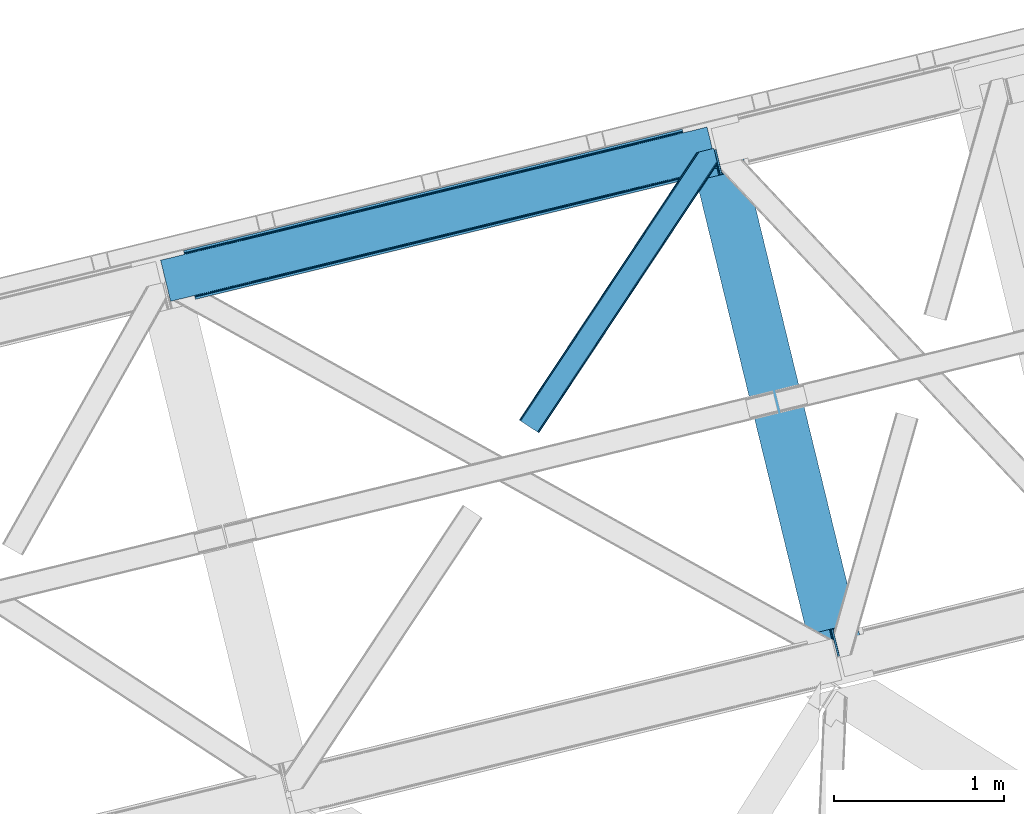
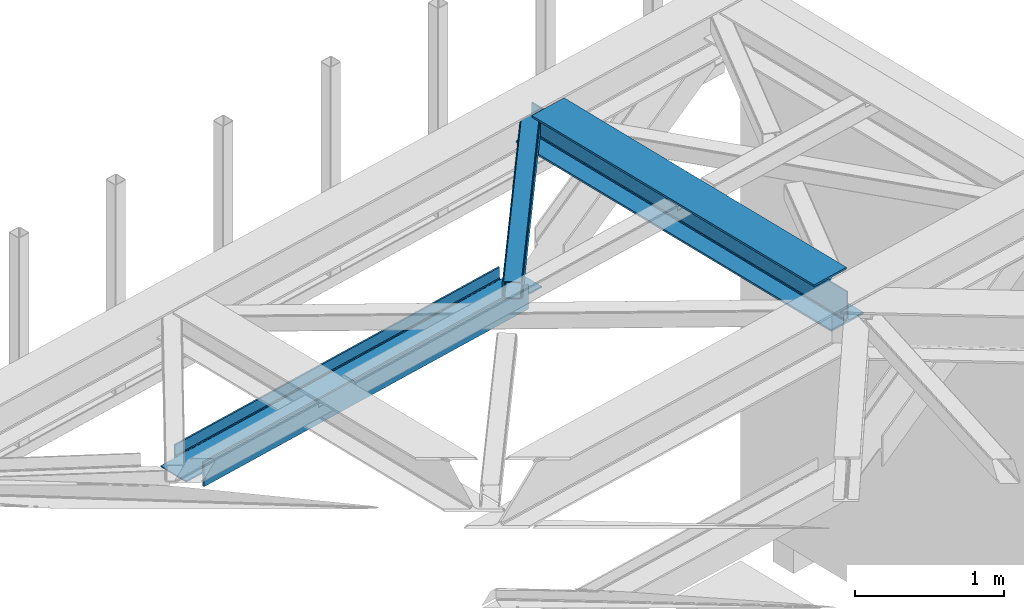
# One storey, part 60 of 66: 2 members, 1 beam.
"""IFC4 building model written with IfcOpenShell, lengths in millimetres."""

from ifc_helpers import new_model, entity, si_unit, converted_unit, derived_unit, direction, frame, origin, place, context, subcontext, project, spatial, triangles, polygons, material, type_object, element, save


model = new_model("IFC4")

# Units and contexts
model_context = context("Model", 3, precision=0.01, world=origin(), true_north=direction((6.12303176911189e-17, 1.0)))
plan_context = context("Plan", 3, precision=0.01, world=origin(), true_north=direction((6.12303176911189e-17, 1.0)))
body_context = subcontext(model_context, "Body", "Model", "MODEL_VIEW")
ifc_project = project(units=[si_unit("LENGTHUNIT", "METRE", prefix="MILLI"), si_unit("AREAUNIT", "SQUARE_METRE"), si_unit("VOLUMEUNIT", "CUBIC_METRE"), converted_unit("PLANEANGLEUNIT", "DEGREE", entity("IfcRatioMeasure", 0.0174532925199433), si_unit("PLANEANGLEUNIT", "RADIAN"), dimensions=[0, 0, 0, 0, 0, 0, 0]), si_unit("MASSUNIT", "GRAM", prefix="KILO"), derived_unit("MASSDENSITYUNIT", [(si_unit("MASSUNIT", "GRAM", prefix="KILO"), 1), (si_unit("LENGTHUNIT", "METRE"), -3)]), derived_unit("MOMENTOFINERTIAUNIT", [(si_unit("LENGTHUNIT", "METRE"), 4)]), si_unit("TIMEUNIT", "SECOND"), si_unit("FREQUENCYUNIT", "HERTZ"), si_unit("THERMODYNAMICTEMPERATUREUNIT", "DEGREE_CELSIUS"), derived_unit("THERMALTRANSMITTANCEUNIT", [(si_unit("MASSUNIT", "GRAM", prefix="KILO"), 1), (si_unit("THERMODYNAMICTEMPERATUREUNIT", "KELVIN"), -1), (si_unit("TIMEUNIT", "SECOND"), -3)]), derived_unit("VOLUMETRICFLOWRATEUNIT", [(si_unit("LENGTHUNIT", "METRE"), 3), (si_unit("TIMEUNIT", "SECOND"), -1)]), derived_unit("MASSFLOWRATEUNIT", [(si_unit("MASSUNIT", "GRAM", prefix="KILO"), 1), (si_unit("TIMEUNIT", "SECOND"), -1)]), derived_unit("ROTATIONALFREQUENCYUNIT", [(si_unit("TIMEUNIT", "SECOND"), -1)]), si_unit("ELECTRICCURRENTUNIT", "AMPERE"), si_unit("ELECTRICVOLTAGEUNIT", "VOLT"), si_unit("POWERUNIT", "WATT"), si_unit("FORCEUNIT", "NEWTON", prefix="KILO"), si_unit("ILLUMINANCEUNIT", "LUX"), si_unit("LUMINOUSFLUXUNIT", "LUMEN"), si_unit("LUMINOUSINTENSITYUNIT", "CANDELA"), derived_unit("USERDEFINED", [(si_unit("MASSUNIT", "GRAM", prefix="KILO"), -1), (si_unit("LENGTHUNIT", "METRE"), -2), (si_unit("TIMEUNIT", "SECOND"), 3), (si_unit("LUMINOUSFLUXUNIT", "LUMEN"), 1)]), derived_unit("LINEARVELOCITYUNIT", [(si_unit("LENGTHUNIT", "METRE"), 1), (si_unit("TIMEUNIT", "SECOND"), -1)]), si_unit("PRESSUREUNIT", "PASCAL"), derived_unit("USERDEFINED", [(si_unit("LENGTHUNIT", "METRE"), -2), (si_unit("MASSUNIT", "GRAM", prefix="KILO"), 1), (si_unit("TIMEUNIT", "SECOND"), -2)]), derived_unit("LINEARFORCEUNIT", [(si_unit("MASSUNIT", "GRAM", prefix="KILO"), 1), (si_unit("LENGTHUNIT", "METRE"), 1), (si_unit("TIMEUNIT", "SECOND"), -2), (si_unit("LENGTHUNIT", "METRE"), -1)]), derived_unit("PLANARFORCEUNIT", [(si_unit("MASSUNIT", "GRAM", prefix="KILO"), 1), (si_unit("LENGTHUNIT", "METRE"), 1), (si_unit("TIMEUNIT", "SECOND"), -2), (si_unit("LENGTHUNIT", "METRE"), -2)])], contexts=[model_context, plan_context])

# Site, building, storey
site_placement = place(None, origin())
site = spatial("IfcSite", under=ifc_project, at=site_placement, CompositionType="ELEMENT")
building_placement = place(site_placement, origin())
building = spatial("IfcBuilding", under=site, at=building_placement, CompositionType="ELEMENT")
storey_placement = place(building_placement, frame((0.0, 0.0, 19800.0)))
storey = spatial("IfcBuildingStorey", under=building, at=storey_placement, Name="06", CompositionType="ELEMENT", Elevation=19800.0)

# Beam
ifc_material = material(Name="Metal painted (White)")
beam_type = type_object("IfcBeamType", PredefinedType="BEAM")
beam_placement = place(storey_placement, frame((-3043.28, 17053.1, 3807.02)))
element("IfcBeam", 1, at=beam_placement, inside=storey, type_object=beam_type, material=ifc_material, ObjectType="Steel Beam", PredefinedType="BEAM", context=body_context, shape_type="Tessellation", body=[
    polygons([(1018.16648378329, 71.0478278971, 15.5000000000008), (1018.16648378329, 71.0478278971, 0.0), (291.465617442441, 3052.25531830421, 0.0), (291.46561744244, 3052.25531830421, 15.5000000000008), (894.779372399327, 40.970914087327, 15.5000000000008), (168.078506058477, 3022.17840449444, 15.5000000000008), (888.087028625373, 39.3395844888221, 16.8701684147984), (161.386162284522, 3020.54707489593, 16.8701684147984), (882.413533524753, 37.9566100336519, 20.7720779386391), (155.712667183902, 3019.16410044076, 20.7720779386391), (878.622625296174, 37.032536045914, 26.6116982174294), (151.921758955324, 3018.24002645303, 26.6116982174294), (877.29143535278, 36.7080444135029, 33.500000000001), (150.59056901193, 3017.91553482061, 33.500000000001), (140.875048430515, 3015.54727389071, 33.500000000001), (140.875048430516, 3015.54727389071, 259.000000000002), (150.590569011928, 3017.91553482061, 259.000000000002), (5.41433564649196e-13, 2981.20749040711, 0.0), (1.08286712929839e-12, 2981.20749040711, 15.4999999999965), (123.387111383957, 3011.28440421688, 15.5000000000008), (130.079455157929, 3012.91573381539, 16.8701684147984), (135.752950258545, 3014.29870827056, 20.7720779386391), (139.543858487118, 3015.22278225829, 26.6116982174294), (877.291435352778, 36.7080444135029, 259.000000000002), (867.575914771367, 34.3397834835992, 259.000000000002), (867.575914771365, 34.3397834835992, 33.500000000001), (866.244724827968, 34.0152918511816, 26.6116982174294), (862.453816599396, 33.0912178634502, 20.7720779386391), (856.78032149878, 31.70824340828, 16.8701684147984), (850.087977724808, 30.0769138097708, 15.5000000000008), (726.700866340852, -2.16573425859679e-12, 15.4999999999965), (726.700866340851, -2.16573425859679e-12, 0.0), (838.124523615906, 197.385937999179, 259.069791973884), (186.469722099963, 2870.72539801218, 259.000000000002), (186.693115201815, 2869.8089536072, 259.617303331124), (186.705504045442, 2869.75812937344, 266.500003008253), (837.97934480814, 197.9814160017, 266.500002998871), (837.979694928892, 197.979979696968, 260.000004007589), (828.499586345875, 194.645865944432, 259.006343171919), (828.276216326112, 195.562317481909, 259.617303331124), (828.263827482483, 195.613141715687, 266.500003008253), (176.989986719785, 2867.38985508742, 266.500002998871), (176.989636599033, 2867.39129139215, 260.000004007589), (176.844830940693, 2867.98534020594, 259.07612046749), (176.754201518551, 2868.35713708228, 259.000000000002), (839.310832678069, 198.30468544639, 273.388305639783), (843.101109266761, 199.231350618303, 279.227924098781), (848.7741802143, 200.616065081979, 283.129832400619), (855.466371895431, 202.248018612794, 284.500000377228), (978.853400583269, 232.325271667903, 284.500000138971), (978.851730776618, 232.332121736637, 299.999995328161), (687.386308679348, 161.283492472594, 299.999995890962), (687.387978485999, 161.276642403861, 284.500000701776), (810.775007173834, 191.35389545897, 284.500000463519), (817.467494069994, 192.984637925553, 283.129832461069), (823.141405718745, 194.365903570076, 279.227924137322), (826.932940505739, 195.28740721937, 273.388305663684), (175.658498849857, 2867.06658564273, 273.388305639783), (171.868222261161, 2866.13992047082, 279.227924098781), (166.195151313635, 2864.75520600714, 283.129832400619), (159.502959632485, 2863.12325247633, 284.500000377228), (36.115930944656, 2833.04599942122, 284.500000138971), (36.117600751305, 2833.03914935249, 299.999995328161), (327.583022848576, 2904.08777861653, 299.999995890962), (327.581353041926, 2904.09462868526, 284.500000701776), (204.194324354083, 2874.01737563015, 284.500000463519), (197.501837457941, 2872.38663316357, 283.129832461069), (191.827925809177, 2871.00536751904, 279.227924137322), (188.036391022187, 2870.08386386975, 273.388305663684)], [[[1, 2, 3, 4]], [[5, 1, 4, 6]], [[7, 5, 6, 8]], [[9, 7, 8, 10]], [[11, 9, 10, 12]], [[13, 11, 12, 14]], [[15, 16, 17, 14, 12, 10, 8, 6, 4, 3, 18, 19, 20, 21, 22, 23]], [[13, 24, 25, 26, 27, 28, 29, 30, 31, 32, 2, 1, 5, 7, 9, 11]], [[2, 32, 18, 3]], [[32, 31, 19, 18]], [[31, 30, 20, 19]], [[27, 26, 15, 23]], [[28, 27, 23, 22]], [[29, 28, 22, 21]], [[30, 29, 21, 20]], [[33, 24, 13, 14, 17, 34, 35, 36, 37, 38]], [[25, 39, 40, 41, 42, 43, 44, 16, 15, 26]], [[39, 25, 24, 33]], [[45, 34, 17, 16]], [[41, 40, 38, 37, 46, 47, 48, 49, 50, 51, 52, 53, 54, 55, 56, 57]], [[42, 58, 59, 60, 61, 62, 63, 64, 65, 66, 67, 68, 69, 36, 35, 43]], [[46, 37, 36, 69]], [[47, 46, 69, 68]], [[48, 47, 68, 67]], [[49, 48, 67, 66]], [[50, 49, 66, 65]], [[51, 50, 65, 64]], [[52, 51, 64, 63]], [[53, 52, 63, 62]], [[54, 53, 62, 61]], [[55, 54, 61, 60]], [[56, 55, 60, 59]], [[57, 56, 59, 58]], [[41, 57, 58, 42]]], closed=False),
])

# Members
member_type_1 = type_object("IfcMemberType", PredefinedType="BRACE")
member_1_placement = place(storey_placement, frame((-4050.77, 18401.58, 3823.02)))
element("IfcMember", 2, at=member_1_placement, inside=storey, type_object=member_type_1, ObjectType="Steel Horizontal Brace", PredefinedType="BRACE", context=body_context, shape_type="Tessellation", body=[
    triangles([(1012.13822021484, 1571.4587310791, 0.0), (1045.99690933228, 1432.55790710449, 0.0), (14.5796333312987, 67.7191223144546, 0.0), (102.080397033692, 9.67499084472729, 0.0), (1.10807189941397, 76.6569488525383, 10.8016662597656), (0.0, 77.3929504394546, 17.4989318847656), (1043.79529953003, 1650.83760681152, 17.4989318847656), (1007.73296585083, 1592.73185119629, 9.25757446288844), (4.27125091552716, 74.5605651855476, 5.12526855468604), (1007.87191085815, 1593.1829864502, 9.49942016601563), (1007.5829750061, 1592.24815979004, 8.99945068359375), (1007.43734436035, 1591.76446838379, 8.74132690429542), (1007.29839935303, 1591.31333312989, 8.49948120117188), (1008.14776611328, 1587.8298248291, 5.12526855468604), (1046.0907989502, 1651.39571228027, 10.8691040039048), (1046.56518859863, 1651.51198425293, 9.49942016601563), (1009.97875900269, 1580.31865539551, 1.33247680663771), (9.00003204345694, 71.4212219238289, 1.33247680663771), (1043.79529953003, 1650.83760681152, 122.499499511716), (0.0, 77.3929504394546, 122.499499511716), (1045.70215988159, 1651.30269470215, 129.196765136716), (1.10807189941397, 76.6569488525383, 129.196765136716), (1051.1335144043, 1652.62586975098, 134.873162841795), (4.27125091552716, 74.5605651855476, 134.873162841795), (1059.25772781372, 1654.60481872559, 138.668280029295), (9.00003204345694, 71.4212219238289, 138.668280029295), (1068.84609603882, 1656.94421081543, 139.998431396481), (14.5796333312987, 67.7191223144546, 139.998431396481), (1012.24141159058, 1575.25849914551, 9.49942016601563), (1011.99578704834, 1574.65621032715, 9.42268066406177), (1012.03008728027, 1573.63069152832, 9.11572265625), (1012.0707824707, 1572.60052185059, 8.80643920898365), (1012.10973358154, 1571.57732849121, 8.49948120117188), (1065.96342315674, 1656.23960266114, 9.49942016601563), (14.8357223510743, 67.5516906738303, 8.33204956054396), (20.4150329589843, 63.8495910644524, 6.99957275390625), (1014.39534988403, 1562.19883117676, 6.99957275390625), (10.1022903442381, 70.6898712158218, 12.1248413085923), (1061.15121688843, 1655.06758117676, 12.1248413085923), (1012.24228363037, 1571.03317565918, 8.41343994140334), (1055.7242225647, 1653.74440612793, 17.8035644531228), (1053.81300201416, 1653.27931823731, 24.4985046386719), (6.94376220703134, 72.7874176025398, 17.8035644531228), (5.83074874877912, 73.5234191894524, 24.4985046386719), (1043.73948898315, 1441.81780700684, 6.99957275390625), (96.244997406006, 13.5445220947258, 6.99957275390625), (1045.89284591675, 1432.98578796387, 8.41343994140334), (1046.02539596558, 1432.44163513184, 8.49948120117188), (1050.83643951416, 1412.70330505371, 8.49948120117188), (1049.98707275391, 1416.18913879395, 5.12526855468604), (1048.15637054443, 1423.69798278809, 1.33247680663771), (1053.81300201416, 1653.27931823731, 115.49992675781), (5.83074874877912, 73.5234191894524, 115.49992675781), (1069.28008117676, 1657.04885559082, 131.666381835938), (1078.86844940186, 1659.38592224121, 132.998858642575), (20.4150329589843, 63.8495910644524, 132.998858642575), (14.8357223510743, 67.5516906738303, 131.666381835938), (1061.15121688843, 1655.06758117676, 127.873590087889), (10.1022903442381, 70.6898712158218, 127.873590087889), (1055.7242225647, 1653.74440612793, 122.19719238281), (6.94376220703134, 72.7874176025398, 122.19719238281), (1145.26875686646, 1675.57098083496, 139.998431396481), (1145.26875686646, 1675.57098083496, 132.998858642575), (1161.91250839233, 1607.29375305176, 139.998431396481), (102.080397033692, 9.67499084472729, 139.998431396481), (1159.65537872314, 1616.5536529541, 132.998858642575), (96.244997406006, 13.5445220947258, 132.998858642575), (1164.07226028442, 1598.43382873535, 138.668280029295), (107.659998321533, 5.97289123535302, 138.668280029295), (1165.9029624939, 1590.92265930176, 134.873162841795), (112.388779449463, 2.83354797363427, 134.873162841795), (1167.12614364624, 1585.90436096191, 129.196765136716), (115.551958465576, 0.737164306639897, 129.196765136716), (1167.55576858521, 1584.14167785645, 122.499499511716), (116.660321044922, 0.0, 122.499499511716), (1167.55576858521, 1584.14167785645, 17.4989318847656), (116.660321044922, 0.0, 17.4989318847656), (106.557740020752, 6.7042419433601, 127.873590087889), (109.716268157959, 4.60553283691479, 122.19719238281), (110.829281616211, 3.87069396972583, 115.49992675781), (101.824308013916, 9.84125976562427, 131.666381835938), (115.551958465576, 0.737164306639897, 10.8016662597656), (106.557740020752, 6.7042419433601, 12.1248413085923), (112.388779449463, 2.83354797363427, 5.12526855468604), (110.829281616211, 3.87069396972583, 24.4985046386719), (109.716268157959, 4.60553283691479, 17.8035644531228), (107.659998321533, 5.97289123535302, 1.33247680663771), (101.824308013916, 9.84125976562427, 8.33204956054396), (1165.29834823608, 1593.40157775879, 115.49992675781), (1165.29834823608, 1593.40157775879, 24.4985046386719), (1164.86901397705, 1595.16426086426, 122.19719238281), (1163.64554214478, 1600.1825592041, 127.873590087889), (1161.8148399353, 1607.6937286377, 131.666381835938), (1164.7812286377, 1595.52470397949, 17.868676757811), (1167.54646682739, 1584.18121032715, 16.4989929199219), (1164.67425842285, 1595.96188659668, 16.4989929199219), (1050.96404800415, 1412.49401550293, 8.8831787109375), (1051.5055847168, 1412.90561828614, 9.29943237304542), (1051.768359375, 1413.10328063965, 9.49942016601563), (1162.81652297974, 1579.82333679199, 10.8714294433594), (1161.66310501099, 1578.76061096192, 9.49942016601563), (1160.35097579956, 1595.22007141114, 12.1248413085923), (1046.70355224609, 1430.89521789551, 9.20641479492042), (1046.36229400635, 1431.66726379394, 8.85294799804615), (1047.39885864258, 1431.02776794434, 9.49942016601563), (1157.29360427856, 1596.68742370605, 9.49942016601563)], [[1, 2, 3], [4, 3, 2], [5, 6, 7], [8, 9, 10], [9, 8, 11], [12, 9, 11], [9, 12, 13], [13, 14, 9], [5, 15, 10], [10, 9, 5], [15, 16, 10], [17, 1, 18], [3, 18, 1], [14, 17, 9], [18, 9, 17], [7, 15, 5], [19, 7, 6], [6, 20, 19], [21, 19, 22], [20, 22, 19], [23, 21, 24], [22, 24, 21], [25, 23, 26], [24, 26, 23], [27, 25, 28], [26, 28, 25], [8, 10, 29], [11, 8, 30], [12, 11, 31], [13, 12, 32], [32, 33, 13], [31, 32, 12], [30, 31, 11], [29, 30, 8], [16, 34, 29], [29, 10, 16], [35, 36, 37], [38, 30, 29], [29, 39, 38], [29, 34, 39], [38, 35, 40], [40, 33, 38], [31, 38, 32], [31, 30, 38], [38, 33, 32], [37, 40, 35], [41, 42, 43], [44, 43, 42], [39, 41, 38], [43, 38, 41], [45, 37, 36], [36, 46, 45], [1, 37, 45], [13, 33, 14], [33, 40, 1], [37, 1, 40], [33, 17, 14], [33, 1, 17], [2, 1, 45], [2, 45, 47], [48, 2, 47], [49, 50, 48], [48, 51, 2], [48, 50, 51], [42, 52, 44], [53, 44, 52], [54, 55, 56], [56, 57, 54], [58, 54, 57], [57, 59, 58], [60, 58, 59], [59, 61, 60], [52, 60, 61], [61, 53, 52], [60, 19, 21], [54, 25, 27], [62, 55, 27], [55, 62, 63], [55, 54, 27], [58, 25, 54], [58, 60, 23], [23, 25, 58], [21, 23, 60], [42, 7, 19], [39, 16, 41], [60, 52, 19], [39, 34, 16], [42, 41, 7], [52, 42, 19], [15, 7, 41], [41, 16, 15], [64, 27, 65], [27, 64, 62], [28, 65, 27], [55, 66, 67], [55, 63, 66], [67, 56, 55], [68, 64, 65], [65, 69, 68], [70, 68, 69], [69, 71, 70], [72, 70, 71], [71, 73, 72], [74, 72, 73], [73, 75, 74], [76, 74, 77], [75, 77, 74], [73, 78, 79], [80, 77, 75], [73, 79, 75], [73, 71, 78], [79, 80, 75], [78, 71, 69], [67, 65, 28], [65, 81, 69], [81, 65, 67], [81, 78, 69], [82, 83, 84], [85, 77, 80], [77, 86, 82], [86, 77, 85], [82, 86, 83], [4, 46, 3], [87, 84, 83], [83, 88, 87], [88, 46, 4], [4, 87, 88], [59, 26, 24], [28, 56, 67], [28, 57, 56], [57, 28, 26], [59, 57, 26], [53, 20, 6], [22, 61, 59], [24, 22, 59], [61, 22, 20], [53, 61, 20], [18, 38, 9], [3, 46, 36], [36, 35, 3], [35, 38, 18], [18, 3, 35], [5, 9, 38], [6, 44, 53], [43, 6, 5], [6, 43, 44], [43, 5, 38], [89, 90, 85], [85, 80, 89], [91, 89, 79], [80, 79, 89], [92, 91, 78], [79, 78, 91], [93, 92, 81], [78, 81, 92], [66, 93, 67], [81, 67, 93], [94, 95, 96], [74, 76, 90], [76, 94, 90], [90, 89, 74], [76, 95, 94], [91, 74, 89], [72, 74, 91], [70, 91, 92], [91, 70, 72], [92, 68, 70], [93, 68, 92], [93, 66, 64], [93, 64, 68], [66, 62, 64], [66, 63, 62], [82, 97, 98], [99, 100, 82], [99, 101, 100], [84, 50, 97], [97, 82, 84], [77, 82, 100], [100, 76, 77], [100, 95, 76], [51, 50, 87], [84, 87, 50], [2, 51, 4], [87, 4, 51], [86, 85, 90], [86, 96, 102], [86, 94, 96], [103, 104, 88], [48, 88, 104], [83, 102, 105], [105, 88, 83], [102, 106, 105], [46, 88, 48], [48, 45, 46], [102, 83, 86], [90, 94, 86], [97, 48, 104], [97, 104, 105], [106, 101, 105], [99, 105, 101], [102, 95, 100], [102, 96, 95], [102, 101, 106], [100, 101, 102]]),
])
member_type_2 = type_object("IfcMemberType", PredefinedType="BRACE")
member_2_placement = place(storey_placement, frame((-6161.17, 19176.73, 2512.0)))
element("IfcMember", 3, at=member_2_placement, inside=storey, type_object=member_type_2, ObjectType="Steel Vertical Brace", PredefinedType="BRACE", context=body_context, shape_type="Tessellation", body=[
    polygons([(202.213006515029, 24.6242629021849, 77.7499999999953), (597.31084349256, 120.933540718255, 77.7499999999953), (1133.2837289006, 251.582602017925, 77.7499999999953), (1669.25661430864, 382.231663317597, 77.7499999999953), (2205.22949971669, 512.88072461726, 77.7499999999953), (2741.20238512474, 643.529785916932, 77.7499999999953), (3136.30022210225, 739.839063732998, 77.7499999999953), (3136.30022210225, 739.839063732998, 0.0), (202.213006515025, 24.6242629021849, 0.0), (3139.37896131113, 727.208886977162, 0.0), (205.291745723899, 11.9940861463463, 0.0), (3139.37896131113, 727.208886977162, 199.999999999998), (205.291745723903, 11.9940861463485, 199.999999999998), (3136.30022210225, 739.839063732998, 122.249999999994), (3136.30022210225, 739.839063732998, 199.999999999998), (3135.97573046984, 741.170253676395, 84.6383017825712), (3135.0516564821, 744.96116190497, 90.4779220613573), (3133.93196117233, 749.554584314495, 93.8745154964792), (3133.93196117236, 749.554584314417, 106.125484503402), (3135.0516564821, 744.96116190497, 109.522077938641), (3135.97573046984, 741.170253676395, 115.361698217427), (202.213006515033, 24.6242629021892, 122.249999999994), (201.888514882618, 25.9554528455858, 115.361698217427), (200.964440894883, 29.7463610741609, 109.522077938641), (199.844745585119, 34.339783483636, 106.125484503441), (199.844745585126, 34.3397834836057, 93.8745154965962), (200.964440894884, 29.7463610741609, 90.4779220613573), (201.888514882619, 25.9554528455858, 84.6383017825712), (202.213006515033, 24.6242629021892, 199.999999999998), (2634.00780804313, 617.399973656999, 122.249999999994), (1990.84034555346, 460.621100097393, 122.249999999994), (1347.67288306381, 303.842226537792, 122.249999999994), (704.505420574163, 147.063352978191, 122.249999999994), (2738.57084504939, 654.325379189628, 94.3798315850377), (2736.93951545091, 661.017722963482, 95.7499999999999), (3272.91240085895, 791.66678426315, 95.7499999999999), (3274.54373045746, 784.9744404892, 94.3798315851979), (2202.59795964137, 523.676317889856, 94.3798315852023), (2200.96663004286, 530.36866166381, 95.7499999999999), (1666.62507423332, 393.027256590189, 94.3798315852023), (1664.99374463482, 399.719600364143, 95.7499999999999), (1130.65218882528, 262.378195290517, 94.3798315852023), (1129.02085922678, 269.070539064473, 95.7499999999999), (594.679303417239, 131.729133990851, 94.3798315852023), (593.047973818735, 138.421477764808, 95.7499999999999), (58.7064180091819, 1.08007269117741, 94.3798315852023), (57.075088410676, 7.77241646513144, 95.7499999999999), (2203.98093409654, 518.002822789236, 90.4779220613573), (2739.95381950459, 648.651884088908, 90.4779220613573), (1668.00804868849, 387.353761489569, 90.4779220613573), (1132.03516328045, 256.704700189899, 90.4779220613573), (596.062277872437, 126.055638890125, 90.4779220615175), (2204.90500808427, 514.211914560661, 84.6383017825712), (2740.87789349232, 644.860975860333, 84.6383017825712), (1668.93212267623, 383.562853260994, 84.6383017825712), (1132.95923726819, 252.913791961324, 84.6383017825712), (596.986351860145, 122.264730661656, 84.6383017825712), (58.9696971545985, 6.49720277579036e-12, 93.8745154965962), (3274.80700960288, 783.894367798018, 93.8745154965962), (1990.51585392106, 461.952290040794, 115.361698217427), (2633.68331641071, 618.731163600395, 115.361698217427), (1347.34839143141, 305.173416481191, 115.361698217427), (704.180928941749, 148.394542921588, 115.361698217427), (1989.59177993332, 465.743198269369, 109.522077938641), (2632.75924242298, 622.522071828931, 109.522077938576), (1346.42431744367, 308.964324709768, 109.522077938641), (703.256854954015, 152.185451150165, 109.522077938641), (1988.20880547815, 471.416693369989, 105.620168414796), (2631.3762679678, 628.19556692959, 105.620168414796), (1345.0413429885, 314.637819810386, 105.620168414796), (701.873880498833, 157.858946250817, 105.620168414861), (2629.7449383693, 634.887910703549, 104.249999999998), (3274.54373045746, 784.974440489196, 105.620168414796), (3272.91240085896, 791.66678426315, 104.249999999998), (1986.57747587964, 478.109037143939, 104.249999999998), (1343.41001338999, 321.33016358434, 104.249999999998), (700.242550900338, 164.551290024739, 104.249999999998), (57.0750884106738, 7.77241646513144, 104.249999999998), (58.7064180091873, 1.08007269117957, 105.6201684148), (3274.80700960287, 783.894367798018, 106.125484503402), (58.9696971545985, 0.0, 106.125484503397), (3217.73192119221, 1018.03841381011, 95.7499999999999), (3216.10059159371, 1024.73075758407, 94.3798315852023), (3215.83731244829, 1025.81083027525, 93.8745154965962), (3215.83731244829, 1025.81083027525, 106.125484503397), (3216.10059159371, 1024.73075758407, 105.620168414796), (3217.73192119221, 1018.03841381011, 104.250000000002), (1.89460874392469, 234.144046012093, 104.250000000002), (0.263279145419858, 240.836389786054, 105.620168414796), (1.08286712929839e-12, 241.916462477225, 106.125484503402), (1.08286712929839e-12, 241.916462477225, 93.8745154965962), (0.26327914542419, 240.836389786054, 94.3798315852023), (1.89460874392469, 234.144046012093, 95.7499999999999), (645.06207123359, 390.922919571701, 95.7499999999999), (1288.22953372324, 547.701793131302, 95.7499999999999), (1931.39699621289, 704.480666690907, 95.7499999999999), (2574.56445870255, 861.259540250508, 95.7499999999999), (2681.75903578416, 887.389352510442, 104.250000000002), (2145.78615037611, 756.740291210774, 104.250000000002), (1609.81326496807, 626.091229911107, 104.250000000002), (1073.84037956003, 495.442168611439, 104.250000000002), (537.867494151986, 364.793107311767, 104.250000000002), (1927.45861817149, 720.637413794056, 84.6383017825712), (1927.13412653906, 721.968603737453, 77.7499999999953), (2570.30158902872, 878.747477297058, 77.7499999999953), (2570.62608066114, 877.416287353657, 84.6383017825712), (1284.29115568184, 563.858540234455, 84.6383017825712), (1283.96666404941, 565.189730177852, 77.7499999999953), (641.123693192179, 407.07966667485, 84.6383017825712), (640.799201559763, 408.410856618251, 77.7499999999953), (1928.38269215922, 716.846505565486, 90.4779220613573), (2571.55015464886, 873.625379125126, 90.4779220614179), (1285.21522966957, 560.06763200588, 90.4779220613573), (642.047767179914, 403.288758446279, 90.4779220613573), (1929.76566661439, 711.173010464866, 94.3798315852023), (2572.93312910405, 867.951884024467, 94.3798315852023), (1286.59820412474, 554.39413690526, 94.3798315852023), (643.430741635095, 397.615263345616, 94.3798315851416), (3072.59400308785, 1001.18656737306, 77.7499999999953), (3072.91849472027, 999.855377429661, 84.6383017825712), (3073.84256870799, 996.064469201147, 90.4779220614439), (3074.96226401778, 991.471046791609, 93.8745154965442), (139.755353120759, 280.849668370334, 90.4779220614439), (138.831279133037, 284.640576598848, 84.6383017825712), (138.506787500627, 285.971766542245, 77.7499999999953), (140.875048430544, 276.25624596077, 93.8745154965052), (2680.12770618568, 894.081696284296, 105.620168414956), (2144.15482077761, 763.432634984733, 105.620168414796), (1608.18193536956, 632.783573685065, 105.620168414796), (1072.20904996152, 502.134512385398, 105.620168414796), (536.236164553481, 371.48545108573, 105.620168414796), (2142.77184632243, 769.106130085348, 109.522077938641), (2678.74473173049, 899.755191385025, 109.522077938641), (1606.79896091439, 638.457068785685, 109.522077938641), (1070.82607550635, 507.808007486013, 109.522077938641), (534.853190098284, 377.158946186454, 109.522077938476), (2141.8477723347, 772.897038313923, 115.361698217427), (2677.82065774275, 903.546099613591, 115.361698217427), (1605.87488692666, 642.247977014256, 115.361698217427), (1069.90200151862, 511.598915714588, 115.361698217427), (533.929116110575, 380.949854414921, 115.361698217427), (2141.52328070228, 774.22822825732, 122.249999999994), (2677.49616611034, 904.877289556988, 122.249999999994), (1605.55039529424, 643.579166957652, 122.249999999994), (1069.5775098862, 512.930105657985, 122.249999999994), (533.60462447816, 382.281044358317, 122.249999999994), (3073.84256870796, 996.064469201242, 109.522077938415), (3072.91849472027, 999.855377429661, 115.361698217427), (3072.59400308785, 1001.18656737306, 122.249999999994), (138.506787500631, 285.971766542245, 122.249999999994), (138.831279133042, 284.640576598848, 115.361698217427), (139.755353120737, 280.849668370433, 109.522077938415), (140.875048430552, 276.256245960737, 106.125484503536), (3074.9622640178, 991.471046791483, 106.125484503623), (3072.59400308785, 1001.18656737305, 0.0), (3069.51526387898, 1013.81674412889, 0.0), (3069.51526387898, 1013.81674412889, 199.999999999998), (3072.59400308785, 1001.18656737305, 199.999999999998), (138.506787500633, 285.971766542245, 199.999999999998), (135.428048291758, 298.601943298085, 199.999999999998), (135.428048291758, 298.601943298085, 0.0), (138.506787500633, 285.971766542245, 0.0)], [[[1, 2, 3, 4, 5, 6, 7, 8, 9]], [[9, 8, 10, 11]], [[11, 10, 12, 13]], [[14, 15, 12, 10, 8, 7, 16, 17, 18, 19, 20, 21]], [[22, 23, 24, 25, 26, 27, 28, 1, 9, 11, 13, 29]], [[13, 12, 15, 29]], [[29, 15, 14, 30, 31, 32, 33, 22]], [[34, 35, 36, 37]], [[38, 39, 35, 34]], [[40, 41, 39, 38]], [[42, 43, 41, 40]], [[44, 45, 43, 42]], [[46, 47, 45, 44]], [[48, 38, 34, 49]], [[50, 40, 38, 48]], [[51, 42, 40, 50]], [[52, 44, 42, 51]], [[53, 48, 49, 54]], [[55, 50, 48, 53]], [[56, 51, 50, 55]], [[57, 52, 51, 56]], [[5, 53, 54, 6]], [[4, 55, 53, 5]], [[3, 56, 55, 4]], [[2, 57, 56, 3]], [[17, 16, 54, 49]], [[16, 7, 6, 54]], [[1, 28, 57, 2]], [[28, 27, 52, 57]], [[44, 26, 58, 46]], [[52, 26, 44]], [[26, 52, 27]], [[18, 37, 59]], [[49, 18, 17]], [[34, 18, 49]], [[18, 34, 37]], [[60, 31, 30, 61]], [[62, 32, 31, 60]], [[63, 33, 32, 62]], [[64, 60, 61, 65]], [[66, 62, 60, 64]], [[67, 63, 62, 66]], [[68, 64, 65, 69]], [[70, 66, 64, 68]], [[71, 67, 66, 70]], [[72, 69, 73, 74]], [[75, 68, 69, 72]], [[76, 70, 68, 75]], [[77, 71, 70, 76]], [[78, 79, 71, 77]], [[14, 21, 61, 30]], [[21, 20, 65, 61]], [[69, 19, 80, 73]], [[24, 23, 63, 67]], [[23, 22, 33, 63]], [[25, 79, 81]], [[67, 25, 24]], [[71, 25, 67]], [[25, 71, 79]], [[65, 19, 69]], [[19, 65, 20]], [[19, 18, 59, 80]], [[25, 81, 58, 26]], [[74, 73, 80, 59, 37, 36, 82, 83, 84, 85, 86, 87]], [[47, 46, 58, 81, 79, 78, 88, 89, 90, 91, 92, 93]], [[47, 93, 94, 95, 96, 97, 82, 36, 35, 39, 41, 43, 45]], [[88, 78, 77, 76, 75, 72, 74, 87, 98, 99, 100, 101, 102]], [[103, 104, 105, 106]], [[107, 108, 104, 103]], [[109, 110, 108, 107]], [[111, 103, 106, 112]], [[113, 107, 103, 111]], [[114, 109, 107, 113]], [[115, 111, 112, 116]], [[117, 113, 111, 115]], [[118, 114, 113, 117]], [[97, 116, 83, 82]], [[96, 115, 116, 97]], [[95, 117, 115, 96]], [[94, 118, 117, 95]], [[93, 92, 118, 94]], [[119, 120, 106, 105]], [[120, 121, 112, 106]], [[116, 122, 84, 83]], [[123, 124, 109, 114]], [[124, 125, 110, 109]], [[126, 92, 91]], [[114, 126, 123]], [[118, 126, 114]], [[126, 118, 92]], [[112, 122, 116]], [[122, 112, 121]], [[127, 98, 87, 86]], [[128, 99, 98, 127]], [[129, 100, 99, 128]], [[130, 101, 100, 129]], [[131, 102, 101, 130]], [[89, 88, 102, 131]], [[132, 128, 127, 133]], [[134, 129, 128, 132]], [[135, 130, 129, 134]], [[136, 131, 130, 135]], [[137, 132, 133, 138]], [[139, 134, 132, 137]], [[140, 135, 134, 139]], [[141, 136, 135, 140]], [[142, 137, 138, 143]], [[144, 139, 137, 142]], [[145, 140, 139, 144]], [[146, 141, 140, 145]], [[147, 148, 138, 133]], [[148, 149, 143, 138]], [[150, 151, 141, 146]], [[151, 152, 136, 141]], [[131, 153, 90, 89]], [[136, 153, 131]], [[153, 136, 152]], [[154, 86, 85]], [[133, 154, 147]], [[127, 154, 133]], [[154, 127, 86]], [[85, 84, 122, 154]], [[90, 153, 126, 91]], [[154, 122, 121, 120, 119, 155, 156, 157, 158, 149, 148, 147]], [[153, 152, 151, 150, 159, 160, 161, 162, 125, 124, 123, 126]], [[162, 155, 119, 105, 104, 108, 110, 125]], [[161, 156, 155, 162]], [[150, 146, 145, 144, 142, 143, 149, 158, 159]], [[159, 158, 157, 160]], [[160, 157, 156, 161]]], closed=True),
])

save(model, "model.ifc")
